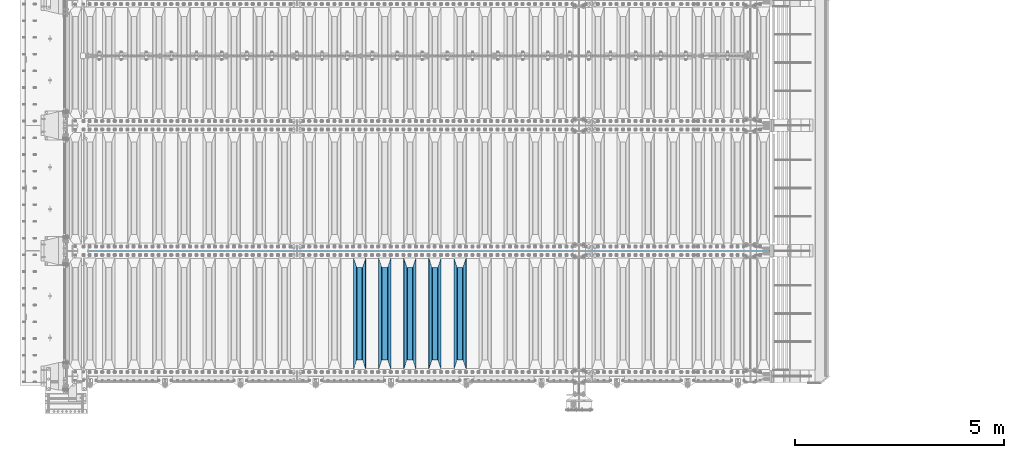
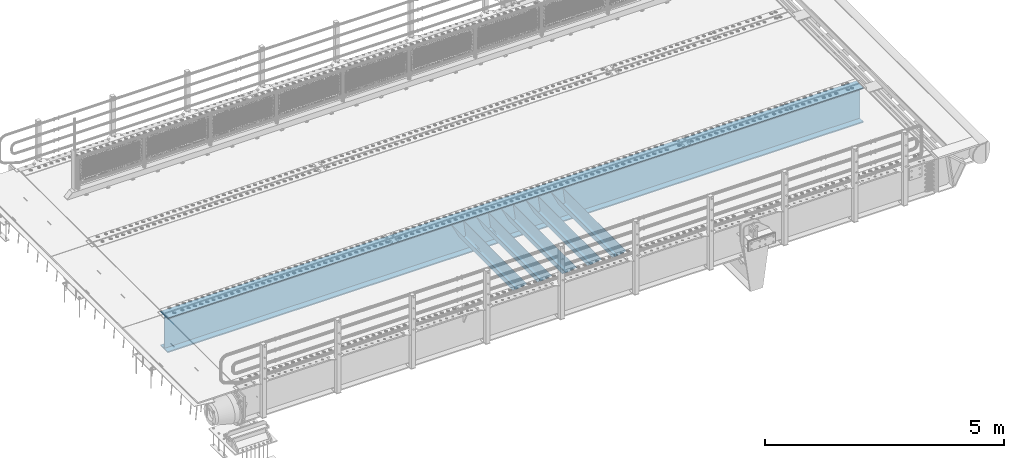
# One storey, part 113 of 247: 6 beams.
"""IFC2X3 building model written with IfcOpenShell, lengths in millimetres."""

from ifc_helpers import new_model, si_unit, frame, origin_with_axes, place, context, subcontext, project, spatial, faceted_brep, material, type_object, element, save


model = new_model("IFC2X3")

# Units and contexts
model_context = context("Model", 3, precision=1e-05, world=origin_with_axes())
body_context = subcontext(model_context, "Body", "Model", "MODEL_VIEW")
ifc_project = project(units=[si_unit("LENGTHUNIT", "METRE", prefix="MILLI"), si_unit("AREAUNIT", "SQUARE_METRE"), si_unit("VOLUMEUNIT", "CUBIC_METRE"), si_unit("MASSUNIT", "GRAM", prefix="KILO"), si_unit("TIMEUNIT", "SECOND"), si_unit("PLANEANGLEUNIT", "RADIAN"), si_unit("SOLIDANGLEUNIT", "STERADIAN"), si_unit("THERMODYNAMICTEMPERATUREUNIT", "DEGREE_CELSIUS"), si_unit("LUMINOUSINTENSITYUNIT", "LUMEN")], contexts=[model_context])

# Site, building, storey
site_placement = place(None, origin_with_axes())
site = spatial("IfcSite", under=ifc_project, at=site_placement, CompositionType="ELEMENT")
building_placement = place(site_placement, origin_with_axes())
building = spatial("IfcBuilding", under=site, at=building_placement, Name="Standard", CompositionType="ELEMENT")
storey_placement = place(building_placement, origin_with_axes())
storey = spatial("IfcBuildingStorey", under=building, at=storey_placement, Name="Undefined", CompositionType="ELEMENT", Elevation=0.0)

# Beams
ifc_material = material(Name="STEEL/S355N")
beam_type_1 = type_object("IfcBeamType", PredefinedType="NOTDEFINED")
beam_1_placement = place(storey_placement, frame((9400.0, 175.0, -115.0), z_axis=(0.0, 0.0, 1.0), x_axis=(0.0, 1.0, 0.0)))
element("IfcBeam", 1, at=beam_1_placement, inside=storey, type_object=beam_type_1, material=ifc_material, context=body_context, shape_type="Brep", body=[
    faceted_brep([(0.0, 150.0, 115.0), (0.0, 143.689999999999, 115.0), (2650.00000000297, 143.689999999999, 115.0), (2650.00000000297, 150.0, 115.0), (2650.00000000297, 142.059565218402, 110.0000000031), (2650.00000000297, 148.369565218403, 110.0000000031), (2441.90079219208, -80.1103600731112, -98.0992078077845), (2437.7588105432, -77.5672621345584, -102.241189456673), (2434.06523489746, -74.4080125315522, -105.934765102404), (2430.91086095089, -70.710272125576, -109.089139048974), (2428.37322971128, -66.5649389910068, -111.626770288588), (2426.51472138054, -62.0739139532889, -113.485278619323), (2425.38102192091, -57.3475956567672, -114.618978078955), (2424.99999999987, -52.5021667386536, -115.0), (2424.99999999987, 52.5021667386536, -115.0), (2425.38102192091, 57.3475956567672, -114.618978078955), (2426.51472138054, 62.0739139532889, -113.485278619323), (2428.37322971128, 66.5649389910068, -111.626770288588), (2430.91086095089, 70.710272125576, -109.089139048974), (2434.06523489746, 74.4080125315522, -105.934765102404), (2437.7588105432, 77.5672621345584, -102.241189456673), (2441.90079219208, 80.1103600731112, -98.0992078077846), (2446.38936140511, 81.9747917625791, -93.6106385947584), (2448.24948500409, 76.2713538057251, -91.7505149957729), (2444.62967112262, 74.76777986261, -95.3703288772456), (2441.28936334126, 72.7168944282894, -98.710636658607), (2438.31067330438, 70.1691124903846, -101.689326695487), (2435.76682334747, 67.1870637758839, -104.233176652398), (2433.72034654133, 63.8440531834895, -106.279653458539), (2432.22154950041, 60.222258798236, -107.778450499454), (2431.30727574265, 56.4107117849089, -108.692724257221), (2430.99999999987, 52.5031078186876, -109.0), (2430.99999999987, -52.5031078186876, -109.0), (2431.30727574265, -56.4107117849089, -108.692724257221), (2432.22154950041, -60.222258798236, -107.778450499454), (2433.72034654133, -63.8440531834895, -106.279653458539), (2435.76682334747, -67.1870637758839, -104.233176652398), (2438.31067330438, -70.1691124903846, -101.689326695487), (2441.28936334126, -72.7168944282894, -98.7106366586071), (2444.62967112262, -74.76777986261, -95.3703288772457), (2448.24948500409, -76.2713538057251, -91.7505149957729), (2650.00000000297, -142.059565218402, 110.0000000031), (2650.00000000297, -148.369565218403, 110.0000000031), (2446.38936140511, -81.9747917625791, -93.6106385947584), (2650.00000000297, -143.689999999999, 115.0), (2650.00000000297, -150.0, 115.0), (0.0, -143.689999999999, 115.0), (0.0, -150.0, 115.0), (0.0, -148.369565218261, 110.000000002663), (203.610638597422, -81.9747917625791, -93.6106385947584), (208.099207810448, -80.1103600731112, -98.0992078077845), (212.241189459336, -77.5672621345584, -102.241189456673), (215.934765105068, -74.4080125315522, -105.934765102404), (219.089139051637, -70.710272125576, -109.089139048974), (221.626770291251, -66.5649389910068, -111.626770288588), (223.485278621985, -62.0739139532889, -113.485278619323), (224.618978081617, -57.3475956567672, -114.618978078955), (225.000000002663, -52.5021667386536, -115.0), (225.000000002663, 52.5021667386536, -115.0), (224.618978081617, 57.3475956567672, -114.618978078955), (223.485278621985, 62.0739139532889, -113.485278619323), (221.626770291251, 66.5649389910068, -111.626770288588), (219.089139051637, 70.710272125576, -109.089139048974), (215.934765105068, 74.4080125315522, -105.934765102404), (212.241189459336, 77.5672621345584, -102.241189456673), (208.099207810448, 80.1103600731112, -98.0992078077846), (203.610638597422, 81.9747917625791, -93.6106385947584), (0.0, 148.369565218261, 110.000000002663), (0.0, 142.05956521826, 110.000000002663), (201.750514998436, 76.2713538057251, -91.7505149957729), (205.370328879908, 74.76777986261, -95.3703288772456), (208.710636661271, 72.7168944282894, -98.710636658607), (211.68932669815, 70.1691124903846, -101.689326695487), (214.233176655061, 67.1870637758839, -104.233176652398), (216.279653461202, 63.8440531834895, -106.279653458539), (217.778450502117, 60.222258798236, -107.778450499454), (218.692724259885, 56.4107117849089, -108.692724257221), (219.000000002663, 52.5031078186876, -109.0), (219.000000002663, -52.5031078186876, -109.0), (218.692724259885, -56.4107117849089, -108.692724257221), (217.778450502117, -60.222258798236, -107.778450499454), (216.279653461202, -63.8440531834895, -106.279653458539), (214.233176655061, -67.1870637758839, -104.233176652398), (211.68932669815, -70.1691124903846, -101.689326695487), (208.710636661271, -72.7168944282894, -98.7106366586071), (205.370328879908, -74.76777986261, -95.3703288772457), (201.750514998436, -76.2713538057251, -91.7505149957729), (0.0, -142.05956521826, 110.000000002663)], [[[0, 1, 2, 3]], [[3, 2, 4, 5]], [[6, 7, 8, 9, 10, 11, 12, 13, 14, 15, 16, 17, 18, 19, 20, 21, 22, 5, 4, 23, 24, 25, 26, 27, 28, 29, 30, 31, 32, 33, 34, 35, 36, 37, 38, 39, 40, 41, 42, 43]], [[44, 45, 42, 41]], [[46, 47, 45, 44]], [[43, 42, 45, 47, 48, 49]], [[6, 43, 49, 50]], [[7, 6, 50, 51]], [[8, 7, 51, 52]], [[9, 8, 52, 53]], [[10, 9, 53, 54]], [[11, 10, 54, 55]], [[12, 11, 55, 56]], [[13, 12, 56, 57]], [[14, 13, 57, 58]], [[15, 14, 58, 59]], [[16, 15, 59, 60]], [[17, 16, 60, 61]], [[18, 17, 61, 62]], [[19, 18, 62, 63]], [[20, 19, 63, 64]], [[21, 20, 64, 65]], [[22, 21, 65, 66]], [[0, 3, 5, 22, 66, 67]], [[1, 0, 67, 68]], [[23, 4, 2, 1, 68, 69]], [[24, 23, 69, 70]], [[25, 24, 70, 71]], [[26, 25, 71, 72]], [[27, 26, 72, 73]], [[28, 27, 73, 74]], [[29, 28, 74, 75]], [[30, 29, 75, 76]], [[31, 30, 76, 77]], [[32, 31, 77, 78]], [[33, 32, 78, 79]], [[34, 33, 79, 80]], [[35, 34, 80, 81]], [[36, 35, 81, 82]], [[37, 36, 82, 83]], [[38, 37, 83, 84]], [[39, 38, 84, 85]], [[40, 39, 85, 86]], [[46, 44, 41, 40, 86, 87]], [[47, 46, 87, 48]], [[86, 85, 84, 83, 82, 81, 80, 79, 78, 77, 76, 75, 74, 73, 72, 71, 70, 69, 68, 67, 66, 65, 64, 63, 62, 61, 60, 59, 58, 57, 56, 55, 54, 53, 52, 51, 50, 49, 48, 87]]]),
])
beam_2_placement = place(storey_placement, frame((8800.0, 175.0, -115.0), z_axis=(0.0, 0.0, 1.0), x_axis=(0.0, 1.0, 0.0)))
element("IfcBeam", 2, at=beam_2_placement, inside=storey, type_object=beam_type_1, material=ifc_material, context=body_context, shape_type="Brep", body=[
    faceted_brep([(0.0, 150.0, 115.0), (0.0, 143.689999999999, 115.0), (2650.00000000297, 143.689999999999, 115.0), (2650.00000000297, 150.0, 115.0), (2650.00000000297, 142.059565218402, 110.0000000031), (2650.00000000297, 148.369565218403, 110.0000000031), (2441.90079219208, -80.1103600731112, -98.0992078077845), (2437.7588105432, -77.5672621345584, -102.241189456673), (2434.06523489746, -74.4080125315522, -105.934765102404), (2430.91086095089, -70.710272125576, -109.089139048974), (2428.37322971128, -66.5649389910068, -111.626770288588), (2426.51472138054, -62.0739139532889, -113.485278619323), (2425.38102192091, -57.3475956567672, -114.618978078955), (2424.99999999987, -52.5021667386536, -115.0), (2424.99999999987, 52.5021667386536, -115.0), (2425.38102192091, 57.3475956567672, -114.618978078955), (2426.51472138054, 62.0739139532889, -113.485278619323), (2428.37322971128, 66.5649389910068, -111.626770288588), (2430.91086095089, 70.710272125576, -109.089139048974), (2434.06523489746, 74.4080125315522, -105.934765102404), (2437.7588105432, 77.5672621345584, -102.241189456673), (2441.90079219208, 80.1103600731112, -98.0992078077846), (2446.38936140511, 81.9747917625791, -93.6106385947584), (2448.24948500409, 76.2713538057251, -91.7505149957729), (2444.62967112262, 74.76777986261, -95.3703288772456), (2441.28936334126, 72.7168944282894, -98.710636658607), (2438.31067330438, 70.1691124903846, -101.689326695487), (2435.76682334747, 67.1870637758839, -104.233176652398), (2433.72034654133, 63.8440531834895, -106.279653458539), (2432.22154950041, 60.222258798236, -107.778450499454), (2431.30727574265, 56.4107117849089, -108.692724257221), (2430.99999999987, 52.5031078186876, -109.0), (2430.99999999987, -52.5031078186876, -109.0), (2431.30727574265, -56.4107117849089, -108.692724257221), (2432.22154950041, -60.222258798236, -107.778450499454), (2433.72034654133, -63.8440531834895, -106.279653458539), (2435.76682334747, -67.1870637758839, -104.233176652398), (2438.31067330438, -70.1691124903846, -101.689326695487), (2441.28936334126, -72.7168944282894, -98.7106366586071), (2444.62967112262, -74.76777986261, -95.3703288772457), (2448.24948500409, -76.2713538057251, -91.7505149957729), (2650.00000000297, -142.059565218402, 110.0000000031), (2650.00000000297, -148.369565218403, 110.0000000031), (2446.38936140511, -81.9747917625791, -93.6106385947584), (2650.00000000297, -143.689999999999, 115.0), (2650.00000000297, -150.0, 115.0), (0.0, -143.689999999999, 115.0), (0.0, -150.0, 115.0), (0.0, -148.369565218261, 110.000000002663), (203.610638597422, -81.9747917625791, -93.6106385947584), (208.099207810448, -80.1103600731112, -98.0992078077845), (212.241189459336, -77.5672621345584, -102.241189456673), (215.934765105068, -74.4080125315522, -105.934765102404), (219.089139051637, -70.710272125576, -109.089139048974), (221.626770291251, -66.5649389910068, -111.626770288588), (223.485278621985, -62.0739139532889, -113.485278619323), (224.618978081617, -57.3475956567672, -114.618978078955), (225.000000002663, -52.5021667386536, -115.0), (225.000000002663, 52.5021667386536, -115.0), (224.618978081617, 57.3475956567672, -114.618978078955), (223.485278621985, 62.0739139532889, -113.485278619323), (221.626770291251, 66.5649389910068, -111.626770288588), (219.089139051637, 70.710272125576, -109.089139048974), (215.934765105068, 74.4080125315522, -105.934765102404), (212.241189459336, 77.5672621345584, -102.241189456673), (208.099207810448, 80.1103600731112, -98.0992078077846), (203.610638597422, 81.9747917625791, -93.6106385947584), (0.0, 148.369565218261, 110.000000002663), (0.0, 142.05956521826, 110.000000002663), (201.750514998436, 76.2713538057251, -91.7505149957729), (205.370328879908, 74.76777986261, -95.3703288772456), (208.710636661271, 72.7168944282894, -98.710636658607), (211.68932669815, 70.1691124903846, -101.689326695487), (214.233176655061, 67.1870637758839, -104.233176652398), (216.279653461202, 63.8440531834895, -106.279653458539), (217.778450502117, 60.222258798236, -107.778450499454), (218.692724259885, 56.4107117849089, -108.692724257221), (219.000000002663, 52.5031078186876, -109.0), (219.000000002663, -52.5031078186876, -109.0), (218.692724259885, -56.4107117849089, -108.692724257221), (217.778450502117, -60.222258798236, -107.778450499454), (216.279653461202, -63.8440531834895, -106.279653458539), (214.233176655061, -67.1870637758839, -104.233176652398), (211.68932669815, -70.1691124903846, -101.689326695487), (208.710636661271, -72.7168944282894, -98.7106366586071), (205.370328879908, -74.76777986261, -95.3703288772457), (201.750514998436, -76.2713538057251, -91.7505149957729), (0.0, -142.05956521826, 110.000000002663)], [[[0, 1, 2, 3]], [[3, 2, 4, 5]], [[6, 7, 8, 9, 10, 11, 12, 13, 14, 15, 16, 17, 18, 19, 20, 21, 22, 5, 4, 23, 24, 25, 26, 27, 28, 29, 30, 31, 32, 33, 34, 35, 36, 37, 38, 39, 40, 41, 42, 43]], [[44, 45, 42, 41]], [[46, 47, 45, 44]], [[43, 42, 45, 47, 48, 49]], [[6, 43, 49, 50]], [[7, 6, 50, 51]], [[8, 7, 51, 52]], [[9, 8, 52, 53]], [[10, 9, 53, 54]], [[11, 10, 54, 55]], [[12, 11, 55, 56]], [[13, 12, 56, 57]], [[14, 13, 57, 58]], [[15, 14, 58, 59]], [[16, 15, 59, 60]], [[17, 16, 60, 61]], [[18, 17, 61, 62]], [[19, 18, 62, 63]], [[20, 19, 63, 64]], [[21, 20, 64, 65]], [[22, 21, 65, 66]], [[0, 3, 5, 22, 66, 67]], [[1, 0, 67, 68]], [[23, 4, 2, 1, 68, 69]], [[24, 23, 69, 70]], [[25, 24, 70, 71]], [[26, 25, 71, 72]], [[27, 26, 72, 73]], [[28, 27, 73, 74]], [[29, 28, 74, 75]], [[30, 29, 75, 76]], [[31, 30, 76, 77]], [[32, 31, 77, 78]], [[33, 32, 78, 79]], [[34, 33, 79, 80]], [[35, 34, 80, 81]], [[36, 35, 81, 82]], [[37, 36, 82, 83]], [[38, 37, 83, 84]], [[39, 38, 84, 85]], [[40, 39, 85, 86]], [[46, 44, 41, 40, 86, 87]], [[47, 46, 87, 48]], [[86, 85, 84, 83, 82, 81, 80, 79, 78, 77, 76, 75, 74, 73, 72, 71, 70, 69, 68, 67, 66, 65, 64, 63, 62, 61, 60, 59, 58, 57, 56, 55, 54, 53, 52, 51, 50, 49, 48, 87]]]),
])
beam_3_placement = place(storey_placement, frame((8200.0, 175.0, -115.0), z_axis=(0.0, 0.0, 1.0), x_axis=(0.0, 1.0, 0.0)))
element("IfcBeam", 3, at=beam_3_placement, inside=storey, type_object=beam_type_1, material=ifc_material, context=body_context, shape_type="Brep", body=[
    faceted_brep([(0.0, 150.0, 115.0), (0.0, 143.689999999999, 115.0), (2650.00000000297, 143.689999999999, 115.0), (2650.00000000297, 150.0, 115.0), (2650.00000000297, 142.059565218402, 110.0000000031), (2650.00000000297, 148.369565218403, 110.0000000031), (2441.90079219208, -80.1103600731112, -98.0992078077845), (2437.7588105432, -77.5672621345584, -102.241189456673), (2434.06523489746, -74.4080125315522, -105.934765102404), (2430.91086095089, -70.710272125576, -109.089139048974), (2428.37322971128, -66.5649389910068, -111.626770288588), (2426.51472138054, -62.0739139532889, -113.485278619323), (2425.38102192091, -57.3475956567672, -114.618978078955), (2424.99999999987, -52.5021667386536, -115.0), (2424.99999999987, 52.5021667386536, -115.0), (2425.38102192091, 57.3475956567672, -114.618978078955), (2426.51472138054, 62.0739139532889, -113.485278619323), (2428.37322971128, 66.5649389910068, -111.626770288588), (2430.91086095089, 70.710272125576, -109.089139048974), (2434.06523489746, 74.4080125315522, -105.934765102404), (2437.7588105432, 77.5672621345584, -102.241189456673), (2441.90079219208, 80.1103600731112, -98.0992078077846), (2446.38936140511, 81.9747917625791, -93.6106385947584), (2448.24948500409, 76.2713538057251, -91.7505149957729), (2444.62967112262, 74.76777986261, -95.3703288772456), (2441.28936334126, 72.7168944282894, -98.710636658607), (2438.31067330438, 70.1691124903846, -101.689326695487), (2435.76682334747, 67.1870637758839, -104.233176652398), (2433.72034654133, 63.8440531834895, -106.279653458539), (2432.22154950041, 60.222258798236, -107.778450499454), (2431.30727574265, 56.4107117849089, -108.692724257221), (2430.99999999987, 52.5031078186876, -109.0), (2430.99999999987, -52.5031078186876, -109.0), (2431.30727574265, -56.4107117849089, -108.692724257221), (2432.22154950041, -60.222258798236, -107.778450499454), (2433.72034654133, -63.8440531834895, -106.279653458539), (2435.76682334747, -67.1870637758839, -104.233176652398), (2438.31067330438, -70.1691124903846, -101.689326695487), (2441.28936334126, -72.7168944282894, -98.7106366586071), (2444.62967112262, -74.76777986261, -95.3703288772457), (2448.24948500409, -76.2713538057251, -91.7505149957729), (2650.00000000297, -142.059565218402, 110.0000000031), (2650.00000000297, -148.369565218403, 110.0000000031), (2446.38936140511, -81.9747917625791, -93.6106385947584), (2650.00000000297, -143.689999999999, 115.0), (2650.00000000297, -150.0, 115.0), (0.0, -143.689999999999, 115.0), (0.0, -150.0, 115.0), (0.0, -148.369565218261, 110.000000002663), (203.610638597422, -81.9747917625791, -93.6106385947584), (208.099207810448, -80.1103600731112, -98.0992078077845), (212.241189459336, -77.5672621345584, -102.241189456673), (215.934765105068, -74.4080125315522, -105.934765102404), (219.089139051637, -70.710272125576, -109.089139048974), (221.626770291251, -66.5649389910068, -111.626770288588), (223.485278621985, -62.0739139532889, -113.485278619323), (224.618978081617, -57.3475956567672, -114.618978078955), (225.000000002663, -52.5021667386536, -115.0), (225.000000002663, 52.5021667386536, -115.0), (224.618978081617, 57.3475956567672, -114.618978078955), (223.485278621985, 62.0739139532889, -113.485278619323), (221.626770291251, 66.5649389910068, -111.626770288588), (219.089139051637, 70.710272125576, -109.089139048974), (215.934765105068, 74.4080125315522, -105.934765102404), (212.241189459336, 77.5672621345584, -102.241189456673), (208.099207810448, 80.1103600731112, -98.0992078077846), (203.610638597422, 81.9747917625791, -93.6106385947584), (0.0, 148.369565218261, 110.000000002663), (0.0, 142.05956521826, 110.000000002663), (201.750514998436, 76.2713538057251, -91.7505149957729), (205.370328879908, 74.76777986261, -95.3703288772456), (208.710636661271, 72.7168944282894, -98.710636658607), (211.68932669815, 70.1691124903846, -101.689326695487), (214.233176655061, 67.1870637758839, -104.233176652398), (216.279653461202, 63.8440531834895, -106.279653458539), (217.778450502117, 60.222258798236, -107.778450499454), (218.692724259885, 56.4107117849089, -108.692724257221), (219.000000002663, 52.5031078186876, -109.0), (219.000000002663, -52.5031078186876, -109.0), (218.692724259885, -56.4107117849089, -108.692724257221), (217.778450502117, -60.222258798236, -107.778450499454), (216.279653461202, -63.8440531834895, -106.279653458539), (214.233176655061, -67.1870637758839, -104.233176652398), (211.68932669815, -70.1691124903846, -101.689326695487), (208.710636661271, -72.7168944282894, -98.7106366586071), (205.370328879908, -74.76777986261, -95.3703288772457), (201.750514998436, -76.2713538057251, -91.7505149957729), (0.0, -142.05956521826, 110.000000002663)], [[[0, 1, 2, 3]], [[3, 2, 4, 5]], [[6, 7, 8, 9, 10, 11, 12, 13, 14, 15, 16, 17, 18, 19, 20, 21, 22, 5, 4, 23, 24, 25, 26, 27, 28, 29, 30, 31, 32, 33, 34, 35, 36, 37, 38, 39, 40, 41, 42, 43]], [[44, 45, 42, 41]], [[46, 47, 45, 44]], [[43, 42, 45, 47, 48, 49]], [[6, 43, 49, 50]], [[7, 6, 50, 51]], [[8, 7, 51, 52]], [[9, 8, 52, 53]], [[10, 9, 53, 54]], [[11, 10, 54, 55]], [[12, 11, 55, 56]], [[13, 12, 56, 57]], [[14, 13, 57, 58]], [[15, 14, 58, 59]], [[16, 15, 59, 60]], [[17, 16, 60, 61]], [[18, 17, 61, 62]], [[19, 18, 62, 63]], [[20, 19, 63, 64]], [[21, 20, 64, 65]], [[22, 21, 65, 66]], [[0, 3, 5, 22, 66, 67]], [[1, 0, 67, 68]], [[23, 4, 2, 1, 68, 69]], [[24, 23, 69, 70]], [[25, 24, 70, 71]], [[26, 25, 71, 72]], [[27, 26, 72, 73]], [[28, 27, 73, 74]], [[29, 28, 74, 75]], [[30, 29, 75, 76]], [[31, 30, 76, 77]], [[32, 31, 77, 78]], [[33, 32, 78, 79]], [[34, 33, 79, 80]], [[35, 34, 80, 81]], [[36, 35, 81, 82]], [[37, 36, 82, 83]], [[38, 37, 83, 84]], [[39, 38, 84, 85]], [[40, 39, 85, 86]], [[46, 44, 41, 40, 86, 87]], [[47, 46, 87, 48]], [[86, 85, 84, 83, 82, 81, 80, 79, 78, 77, 76, 75, 74, 73, 72, 71, 70, 69, 68, 67, 66, 65, 64, 63, 62, 61, 60, 59, 58, 57, 56, 55, 54, 53, 52, 51, 50, 49, 48, 87]]]),
])
beam_4_placement = place(storey_placement, frame((7600.0, 175.0, -115.0), z_axis=(0.0, 0.0, 1.0), x_axis=(0.0, 1.0, 0.0)))
element("IfcBeam", 4, at=beam_4_placement, inside=storey, type_object=beam_type_1, material=ifc_material, context=body_context, shape_type="Brep", body=[
    faceted_brep([(0.0, 150.0, 115.0), (0.0, 143.689999999999, 115.0), (2650.00000000297, 143.689999999999, 115.0), (2650.00000000297, 150.0, 115.0), (2650.00000000297, 142.059565218402, 110.0000000031), (2650.00000000297, 148.369565218403, 110.0000000031), (2441.90079219208, -80.1103600731112, -98.0992078077845), (2437.7588105432, -77.5672621345584, -102.241189456673), (2434.06523489746, -74.4080125315522, -105.934765102404), (2430.91086095089, -70.710272125576, -109.089139048974), (2428.37322971128, -66.5649389910068, -111.626770288588), (2426.51472138054, -62.0739139532889, -113.485278619323), (2425.38102192091, -57.3475956567672, -114.618978078955), (2424.99999999987, -52.5021667386536, -115.0), (2424.99999999987, 52.5021667386536, -115.0), (2425.38102192091, 57.3475956567672, -114.618978078955), (2426.51472138054, 62.0739139532889, -113.485278619323), (2428.37322971128, 66.5649389910068, -111.626770288588), (2430.91086095089, 70.710272125576, -109.089139048974), (2434.06523489746, 74.4080125315522, -105.934765102404), (2437.7588105432, 77.5672621345584, -102.241189456673), (2441.90079219208, 80.1103600731112, -98.0992078077846), (2446.38936140511, 81.9747917625791, -93.6106385947584), (2448.24948500409, 76.2713538057251, -91.7505149957729), (2444.62967112262, 74.76777986261, -95.3703288772456), (2441.28936334126, 72.7168944282894, -98.710636658607), (2438.31067330438, 70.1691124903846, -101.689326695487), (2435.76682334747, 67.1870637758839, -104.233176652398), (2433.72034654133, 63.8440531834895, -106.279653458539), (2432.22154950041, 60.222258798236, -107.778450499454), (2431.30727574265, 56.4107117849089, -108.692724257221), (2430.99999999987, 52.5031078186876, -109.0), (2430.99999999987, -52.5031078186876, -109.0), (2431.30727574265, -56.4107117849089, -108.692724257221), (2432.22154950041, -60.222258798236, -107.778450499454), (2433.72034654133, -63.8440531834895, -106.279653458539), (2435.76682334747, -67.1870637758839, -104.233176652398), (2438.31067330438, -70.1691124903846, -101.689326695487), (2441.28936334126, -72.7168944282894, -98.7106366586071), (2444.62967112262, -74.76777986261, -95.3703288772457), (2448.24948500409, -76.2713538057251, -91.7505149957729), (2650.00000000297, -142.059565218402, 110.0000000031), (2650.00000000297, -148.369565218403, 110.0000000031), (2446.38936140511, -81.9747917625791, -93.6106385947584), (2650.00000000297, -143.689999999999, 115.0), (2650.00000000297, -150.0, 115.0), (0.0, -143.689999999999, 115.0), (0.0, -150.0, 115.0), (0.0, -148.369565218261, 110.000000002663), (203.610638597422, -81.9747917625791, -93.6106385947584), (208.099207810448, -80.1103600731112, -98.0992078077845), (212.241189459336, -77.5672621345584, -102.241189456673), (215.934765105068, -74.4080125315522, -105.934765102404), (219.089139051637, -70.710272125576, -109.089139048974), (221.626770291251, -66.5649389910068, -111.626770288588), (223.485278621985, -62.0739139532889, -113.485278619323), (224.618978081617, -57.3475956567672, -114.618978078955), (225.000000002663, -52.5021667386536, -115.0), (225.000000002663, 52.5021667386536, -115.0), (224.618978081617, 57.3475956567672, -114.618978078955), (223.485278621985, 62.0739139532889, -113.485278619323), (221.626770291251, 66.5649389910068, -111.626770288588), (219.089139051637, 70.710272125576, -109.089139048974), (215.934765105068, 74.4080125315522, -105.934765102404), (212.241189459336, 77.5672621345584, -102.241189456673), (208.099207810448, 80.1103600731112, -98.0992078077846), (203.610638597422, 81.9747917625791, -93.6106385947584), (0.0, 148.369565218261, 110.000000002663), (0.0, 142.05956521826, 110.000000002663), (201.750514998436, 76.2713538057251, -91.7505149957729), (205.370328879908, 74.76777986261, -95.3703288772456), (208.710636661271, 72.7168944282894, -98.710636658607), (211.68932669815, 70.1691124903846, -101.689326695487), (214.233176655061, 67.1870637758839, -104.233176652398), (216.279653461202, 63.8440531834895, -106.279653458539), (217.778450502117, 60.222258798236, -107.778450499454), (218.692724259885, 56.4107117849089, -108.692724257221), (219.000000002663, 52.5031078186876, -109.0), (219.000000002663, -52.5031078186876, -109.0), (218.692724259885, -56.4107117849089, -108.692724257221), (217.778450502117, -60.222258798236, -107.778450499454), (216.279653461202, -63.8440531834895, -106.279653458539), (214.233176655061, -67.1870637758839, -104.233176652398), (211.68932669815, -70.1691124903846, -101.689326695487), (208.710636661271, -72.7168944282894, -98.7106366586071), (205.370328879908, -74.76777986261, -95.3703288772457), (201.750514998436, -76.2713538057251, -91.7505149957729), (0.0, -142.05956521826, 110.000000002663)], [[[0, 1, 2, 3]], [[3, 2, 4, 5]], [[6, 7, 8, 9, 10, 11, 12, 13, 14, 15, 16, 17, 18, 19, 20, 21, 22, 5, 4, 23, 24, 25, 26, 27, 28, 29, 30, 31, 32, 33, 34, 35, 36, 37, 38, 39, 40, 41, 42, 43]], [[44, 45, 42, 41]], [[46, 47, 45, 44]], [[43, 42, 45, 47, 48, 49]], [[6, 43, 49, 50]], [[7, 6, 50, 51]], [[8, 7, 51, 52]], [[9, 8, 52, 53]], [[10, 9, 53, 54]], [[11, 10, 54, 55]], [[12, 11, 55, 56]], [[13, 12, 56, 57]], [[14, 13, 57, 58]], [[15, 14, 58, 59]], [[16, 15, 59, 60]], [[17, 16, 60, 61]], [[18, 17, 61, 62]], [[19, 18, 62, 63]], [[20, 19, 63, 64]], [[21, 20, 64, 65]], [[22, 21, 65, 66]], [[0, 3, 5, 22, 66, 67]], [[1, 0, 67, 68]], [[23, 4, 2, 1, 68, 69]], [[24, 23, 69, 70]], [[25, 24, 70, 71]], [[26, 25, 71, 72]], [[27, 26, 72, 73]], [[28, 27, 73, 74]], [[29, 28, 74, 75]], [[30, 29, 75, 76]], [[31, 30, 76, 77]], [[32, 31, 77, 78]], [[33, 32, 78, 79]], [[34, 33, 79, 80]], [[35, 34, 80, 81]], [[36, 35, 81, 82]], [[37, 36, 82, 83]], [[38, 37, 83, 84]], [[39, 38, 84, 85]], [[40, 39, 85, 86]], [[46, 44, 41, 40, 86, 87]], [[47, 46, 87, 48]], [[86, 85, 84, 83, 82, 81, 80, 79, 78, 77, 76, 75, 74, 73, 72, 71, 70, 69, 68, 67, 66, 65, 64, 63, 62, 61, 60, 59, 58, 57, 56, 55, 54, 53, 52, 51, 50, 49, 48, 87]]]),
])
beam_5_placement = place(storey_placement, frame((7000.0, 175.0, -115.0), z_axis=(0.0, 0.0, 1.0), x_axis=(0.0, 1.0, 0.0)))
element("IfcBeam", 5, at=beam_5_placement, inside=storey, type_object=beam_type_1, material=ifc_material, context=body_context, shape_type="Brep", body=[
    faceted_brep([(0.0, 150.0, 115.0), (0.0, 143.689999999999, 115.0), (2650.00000000297, 143.689999999999, 115.0), (2650.00000000297, 150.0, 115.0), (2650.00000000297, 142.059565218402, 110.0000000031), (2650.00000000297, 148.369565218403, 110.0000000031), (2441.90079219208, -80.1103600731112, -98.0992078077845), (2437.7588105432, -77.5672621345584, -102.241189456673), (2434.06523489746, -74.4080125315522, -105.934765102404), (2430.91086095089, -70.710272125576, -109.089139048974), (2428.37322971128, -66.5649389910068, -111.626770288588), (2426.51472138054, -62.0739139532889, -113.485278619323), (2425.38102192091, -57.3475956567672, -114.618978078955), (2424.99999999987, -52.5021667386536, -115.0), (2424.99999999987, 52.5021667386536, -115.0), (2425.38102192091, 57.3475956567672, -114.618978078955), (2426.51472138054, 62.0739139532889, -113.485278619323), (2428.37322971128, 66.5649389910068, -111.626770288588), (2430.91086095089, 70.710272125576, -109.089139048974), (2434.06523489746, 74.4080125315522, -105.934765102404), (2437.7588105432, 77.5672621345584, -102.241189456673), (2441.90079219208, 80.1103600731112, -98.0992078077846), (2446.38936140511, 81.9747917625791, -93.6106385947584), (2448.24948500409, 76.2713538057251, -91.7505149957729), (2444.62967112262, 74.76777986261, -95.3703288772456), (2441.28936334126, 72.7168944282894, -98.710636658607), (2438.31067330438, 70.1691124903846, -101.689326695487), (2435.76682334747, 67.1870637758839, -104.233176652398), (2433.72034654133, 63.8440531834895, -106.279653458539), (2432.22154950041, 60.222258798236, -107.778450499454), (2431.30727574265, 56.4107117849089, -108.692724257221), (2430.99999999987, 52.5031078186876, -109.0), (2430.99999999987, -52.5031078186876, -109.0), (2431.30727574265, -56.4107117849089, -108.692724257221), (2432.22154950041, -60.222258798236, -107.778450499454), (2433.72034654133, -63.8440531834895, -106.279653458539), (2435.76682334747, -67.1870637758839, -104.233176652398), (2438.31067330438, -70.1691124903846, -101.689326695487), (2441.28936334126, -72.7168944282894, -98.7106366586071), (2444.62967112262, -74.76777986261, -95.3703288772457), (2448.24948500409, -76.2713538057251, -91.7505149957729), (2650.00000000297, -142.059565218402, 110.0000000031), (2650.00000000297, -148.369565218403, 110.0000000031), (2446.38936140511, -81.9747917625791, -93.6106385947584), (2650.00000000297, -143.689999999999, 115.0), (2650.00000000297, -150.0, 115.0), (0.0, -143.689999999999, 115.0), (0.0, -150.0, 115.0), (0.0, -148.369565218261, 110.000000002663), (203.610638597422, -81.9747917625791, -93.6106385947584), (208.099207810448, -80.1103600731112, -98.0992078077845), (212.241189459336, -77.5672621345584, -102.241189456673), (215.934765105068, -74.4080125315522, -105.934765102404), (219.089139051637, -70.710272125576, -109.089139048974), (221.626770291251, -66.5649389910068, -111.626770288588), (223.485278621985, -62.0739139532889, -113.485278619323), (224.618978081617, -57.3475956567672, -114.618978078955), (225.000000002663, -52.5021667386536, -115.0), (225.000000002663, 52.5021667386536, -115.0), (224.618978081617, 57.3475956567672, -114.618978078955), (223.485278621985, 62.0739139532889, -113.485278619323), (221.626770291251, 66.5649389910068, -111.626770288588), (219.089139051637, 70.710272125576, -109.089139048974), (215.934765105068, 74.4080125315522, -105.934765102404), (212.241189459336, 77.5672621345584, -102.241189456673), (208.099207810448, 80.1103600731112, -98.0992078077846), (203.610638597422, 81.9747917625791, -93.6106385947584), (0.0, 148.369565218261, 110.000000002663), (0.0, 142.05956521826, 110.000000002663), (201.750514998436, 76.2713538057251, -91.7505149957729), (205.370328879908, 74.76777986261, -95.3703288772456), (208.710636661271, 72.7168944282894, -98.710636658607), (211.68932669815, 70.1691124903846, -101.689326695487), (214.233176655061, 67.1870637758839, -104.233176652398), (216.279653461202, 63.8440531834895, -106.279653458539), (217.778450502117, 60.222258798236, -107.778450499454), (218.692724259885, 56.4107117849089, -108.692724257221), (219.000000002663, 52.5031078186876, -109.0), (219.000000002663, -52.5031078186876, -109.0), (218.692724259885, -56.4107117849089, -108.692724257221), (217.778450502117, -60.222258798236, -107.778450499454), (216.279653461202, -63.8440531834895, -106.279653458539), (214.233176655061, -67.1870637758839, -104.233176652398), (211.68932669815, -70.1691124903846, -101.689326695487), (208.710636661271, -72.7168944282894, -98.7106366586071), (205.370328879908, -74.76777986261, -95.3703288772457), (201.750514998436, -76.2713538057251, -91.7505149957729), (0.0, -142.05956521826, 110.000000002663)], [[[0, 1, 2, 3]], [[3, 2, 4, 5]], [[6, 7, 8, 9, 10, 11, 12, 13, 14, 15, 16, 17, 18, 19, 20, 21, 22, 5, 4, 23, 24, 25, 26, 27, 28, 29, 30, 31, 32, 33, 34, 35, 36, 37, 38, 39, 40, 41, 42, 43]], [[44, 45, 42, 41]], [[46, 47, 45, 44]], [[43, 42, 45, 47, 48, 49]], [[6, 43, 49, 50]], [[7, 6, 50, 51]], [[8, 7, 51, 52]], [[9, 8, 52, 53]], [[10, 9, 53, 54]], [[11, 10, 54, 55]], [[12, 11, 55, 56]], [[13, 12, 56, 57]], [[14, 13, 57, 58]], [[15, 14, 58, 59]], [[16, 15, 59, 60]], [[17, 16, 60, 61]], [[18, 17, 61, 62]], [[19, 18, 62, 63]], [[20, 19, 63, 64]], [[21, 20, 64, 65]], [[22, 21, 65, 66]], [[0, 3, 5, 22, 66, 67]], [[1, 0, 67, 68]], [[23, 4, 2, 1, 68, 69]], [[24, 23, 69, 70]], [[25, 24, 70, 71]], [[26, 25, 71, 72]], [[27, 26, 72, 73]], [[28, 27, 73, 74]], [[29, 28, 74, 75]], [[30, 29, 75, 76]], [[31, 30, 76, 77]], [[32, 31, 77, 78]], [[33, 32, 78, 79]], [[34, 33, 79, 80]], [[35, 34, 80, 81]], [[36, 35, 81, 82]], [[37, 36, 82, 83]], [[38, 37, 83, 84]], [[39, 38, 84, 85]], [[40, 39, 85, 86]], [[46, 44, 41, 40, 86, 87]], [[47, 46, 87, 48]], [[86, 85, 84, 83, 82, 81, 80, 79, 78, 77, 76, 75, 74, 73, 72, 71, 70, 69, 68, 67, 66, 65, 64, 63, 62, 61, 60, 59, 58, 57, 56, 55, 54, 53, 52, 51, 50, 49, 48, 87]]]),
])
beam_type_2 = type_object("IfcBeamType", Name="HEA900", PredefinedType="NOTDEFINED")
beam_6_placement = place(storey_placement, frame((10.0, 3000.0, -445.0), z_axis=(0.0, 0.0, 1.0), x_axis=(1.0, 0.0, 0.0)))
element("IfcBeam", 6, at=beam_6_placement, inside=storey, type_object=beam_type_2, material=ifc_material, ObjectType="HEA900", context=body_context, shape_type="Brep", body=[
    faceted_brep([(0.0, 150.0, -445.0), (0.0, 150.0, -415.0), (16807.0, 150.0, -415.0), (16807.0, 150.0, -445.0), (0.0, 8.0, -415.0), (16807.0, 8.0, -415.0), (0.0, 8.0, 415.0), (16807.0, 8.0, 415.0), (0.0, 150.0, 415.0), (16807.0, 150.0, 415.0), (0.0, 150.0, 445.0), (16807.0, 150.0, 445.0), (0.0, -150.0, 445.0), (16807.0, -150.0, 445.0), (0.0, -150.0, 415.0), (16807.0, -150.0, 415.0), (0.0, -8.0, 415.0), (16807.0, -8.0, 415.0), (0.0, -8.0, -415.0), (16807.0, -8.0, -415.0), (0.0, -150.0, -415.0), (16807.0, -150.0, -415.0), (0.0, -150.0, -445.0), (16807.0, -150.0, -445.0)], [[[0, 1, 2, 3]], [[1, 4, 5, 2]], [[4, 6, 7, 5]], [[6, 8, 9, 7]], [[8, 10, 11, 9]], [[10, 12, 13, 11]], [[12, 14, 15, 13]], [[14, 16, 17, 15]], [[16, 18, 19, 17]], [[18, 20, 21, 19]], [[20, 22, 23, 21]], [[22, 0, 3, 23]], [[5, 7, 9, 11, 13, 15, 17, 19, 21, 23, 3, 2]], [[22, 20, 18, 16, 14, 12, 10, 8, 6, 4, 1, 0]]]),
])

save(model, "model.ifc")
